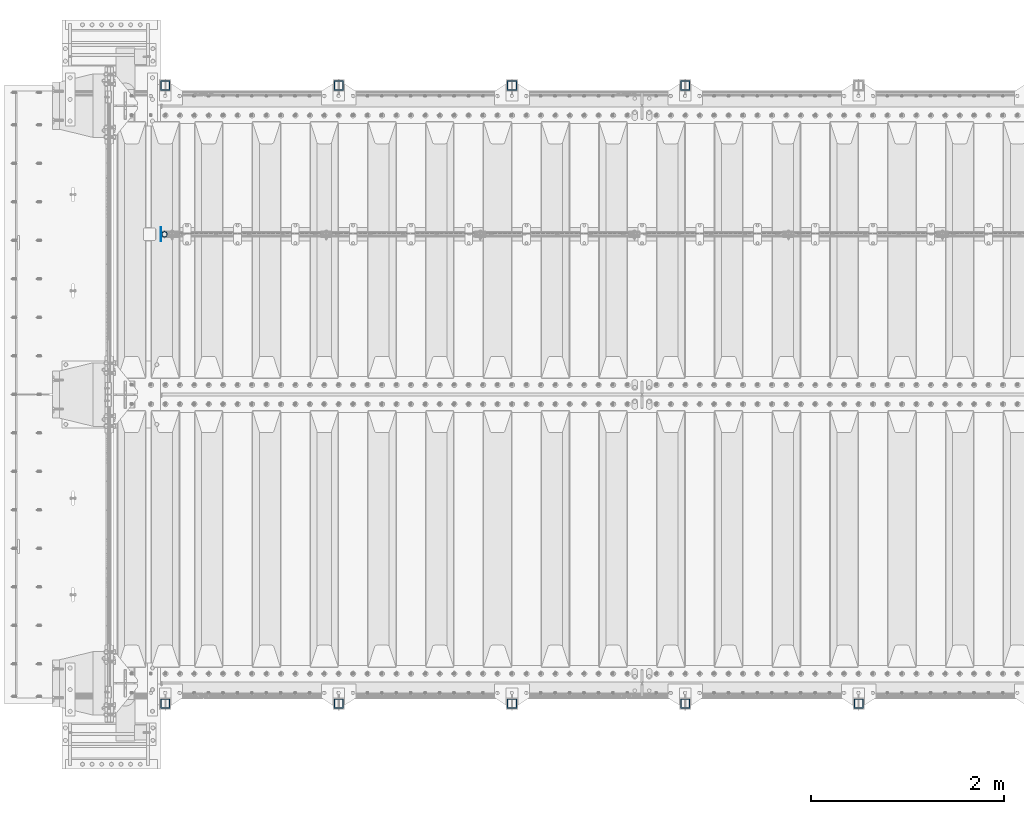
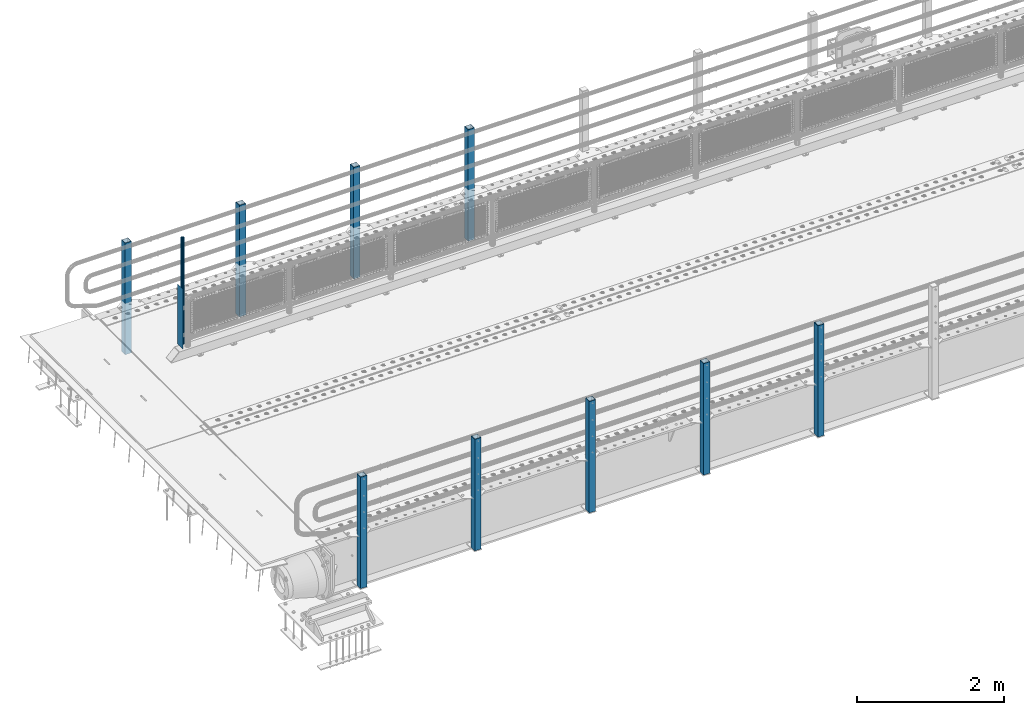
# One storey, part 50 of 208: 11 columns.
"""IFC2X3 building model written with IfcOpenShell, lengths in millimetres."""

from ifc_helpers import new_model, si_unit, frame, origin_with_axes, place, context, subcontext, project, spatial, faceted_brep, material, type_object, element, save


model = new_model("IFC2X3")

# Units and contexts
model_context = context("Model", 3, precision=1e-05, world=origin_with_axes())
body_context = subcontext(model_context, "Body", "Model", "MODEL_VIEW")
ifc_project = project(units=[si_unit("LENGTHUNIT", "METRE", prefix="MILLI"), si_unit("AREAUNIT", "SQUARE_METRE"), si_unit("VOLUMEUNIT", "CUBIC_METRE"), si_unit("MASSUNIT", "GRAM", prefix="KILO"), si_unit("TIMEUNIT", "SECOND"), si_unit("PLANEANGLEUNIT", "RADIAN"), si_unit("SOLIDANGLEUNIT", "STERADIAN"), si_unit("THERMODYNAMICTEMPERATUREUNIT", "DEGREE_CELSIUS"), si_unit("LUMINOUSINTENSITYUNIT", "LUMEN")], contexts=[model_context])

# Site, building, storey
site_placement = place(None, origin_with_axes())
site = spatial("IfcSite", under=ifc_project, at=site_placement, CompositionType="ELEMENT")
building_placement = place(site_placement, origin_with_axes())
building = spatial("IfcBuilding", under=site, at=building_placement, Name="Standard", CompositionType="ELEMENT")
storey_placement = place(building_placement, origin_with_axes())
storey = spatial("IfcBuildingStorey", under=building, at=storey_placement, Name="Undefined", CompositionType="ELEMENT", Elevation=0.0)

# Columns
ifc_material_1 = material(Name="Misc_Undefined")
column_type_1 = type_object("IfcColumnType", PredefinedType="NOTDEFINED")
column_1_placement = place(storey_placement, frame((-41909.0, 4664.5, 238.02), z_axis=(1.0, 0.0, 0.0), x_axis=(0.0, 0.0, 1.0)))
element("IfcColumn", 1, at=column_1_placement, inside=storey, type_object=column_type_1, material=ifc_material_1, context=body_context, shape_type="Brep", body=[
    faceted_brep([(0.0, -25.3500000000004, 0.0), (0.0, -23.4203461491616, 9.70102501045403), (1761.98, -23.4203461491616, 9.70102501045767), (1761.98, -25.3500000000004, 0.0), (0.0, -17.9251569030794, 17.9251569030785), (1761.98, -17.9251569030794, 17.9251569030821), (0.0, -9.70102501045494, 23.4203461491597), (1761.98, -9.70102501045494, 23.4203461491634), (0.0, 0.0, 25.3499999999985), (1761.98, 0.0, 25.3499999999985), (0.0, 9.70102501045494, 23.4203461491597), (1761.98, 9.70102501045494, 23.4203461491634), (0.0, 17.9251569030794, 17.9251569030785), (1761.98, 17.9251569030794, 17.9251569030821), (0.0, 23.4203461491616, 9.70102501045403), (1761.98, 23.4203461491616, 9.70102501045767), (0.0, 25.3500000000004, 0.0), (1761.98, 25.3500000000004, 0.0), (0.0, 23.4203461491616, -9.70102501045403), (1761.98, 23.4203461491616, -9.70102501045767), (0.0, 17.9251569030794, -17.9251569030785), (1761.98, 17.9251569030794, -17.9251569030821), (0.0, 9.70102501045494, -23.4203461491597), (1761.98, 9.70102501045494, -23.4203461491634), (0.0, 0.0, -25.3499999999985), (1761.98, 0.0, -25.3499999999985), (0.0, -9.70102501045494, -23.4203461491597), (1761.98, -9.70102501045494, -23.4203461491634), (0.0, -17.9251569030794, -17.9251569030785), (1761.98, -17.9251569030794, -17.9251569030821), (0.0, -23.4203461491616, -9.70102501045403), (1761.98, -23.4203461491616, -9.70102501045767), (0.0, -30.1499999999996, 0.0), (0.0, -27.8549679052148, -11.5379054858058), (1761.98, -27.8549679052148, -11.5379054858058), (1761.98, -30.1499999999996, 0.0), (0.0, -21.3192694527743, -21.3192694527752), (1761.98, -21.3192694527743, -21.3192694527752), (0.0, -11.5379054858076, -27.8549679052157), (1761.98, -11.5379054858076, -27.8549679052157), (0.0, 0.0, -30.1500000000015), (1761.98, 0.0, -30.1500000000015), (0.0, 11.5379054858076, -27.8549679052157), (1761.98, 11.5379054858076, -27.8549679052157), (0.0, 21.3192694527743, -21.3192694527752), (1761.98, 21.3192694527743, -21.3192694527752), (0.0, 27.8549679052157, -11.5379054858058), (1761.98, 27.8549679052157, -11.5379054858058), (0.0, 30.1499999999996, 0.0), (1761.98, 30.1499999999996, 0.0), (0.0, 27.8549679052157, 11.5379054858058), (1761.98, 27.8549679052157, 11.5379054858058), (0.0, 21.3192694527743, 21.3192694527752), (1761.98, 21.3192694527743, 21.3192694527752), (0.0, 11.5379054858076, 27.8549679052157), (1761.98, 11.5379054858076, 27.8549679052157), (0.0, 0.0, 30.1500000000015), (1761.98, 0.0, 30.1500000000015), (0.0, -11.5379054858076, 27.8549679052157), (1761.98, -11.5379054858076, 27.8549679052157), (0.0, -21.3192694527743, 21.3192694527752), (1761.98, -21.3192694527743, 21.3192694527752), (0.0, -27.8549679052157, 11.5379054858058), (1761.98, -27.8549679052157, 11.5379054858058)], [[[0, 1, 2, 3]], [[1, 4, 5, 2]], [[4, 6, 7, 5]], [[6, 8, 9, 7]], [[8, 10, 11, 9]], [[10, 12, 13, 11]], [[12, 14, 15, 13]], [[14, 16, 17, 15]], [[16, 18, 19, 17]], [[18, 20, 21, 19]], [[20, 22, 23, 21]], [[22, 24, 25, 23]], [[24, 26, 27, 25]], [[26, 28, 29, 27]], [[28, 30, 31, 29]], [[30, 0, 3, 31]], [[32, 33, 34, 35]], [[33, 36, 37, 34]], [[36, 38, 39, 37]], [[38, 40, 41, 39]], [[40, 42, 43, 41]], [[42, 44, 45, 43]], [[44, 46, 47, 45]], [[46, 48, 49, 47]], [[48, 50, 51, 49]], [[50, 52, 53, 51]], [[52, 54, 55, 53]], [[54, 56, 57, 55]], [[56, 58, 59, 57]], [[58, 60, 61, 59]], [[60, 62, 63, 61]], [[62, 32, 35, 63]], [[37, 39, 41, 43, 45, 47, 49, 51, 53, 55, 57, 59, 61, 63, 35, 34], [5, 7, 9, 11, 13, 15, 17, 19, 21, 23, 25, 27, 29, 31, 3, 2]], [[62, 60, 58, 56, 54, 52, 50, 48, 46, 44, 42, 40, 38, 36, 33, 32], [30, 28, 26, 24, 22, 20, 18, 16, 14, 12, 10, 8, 6, 4, 1, 0]]]),
])
column_type_2 = type_object("IfcColumnType", PredefinedType="NOTDEFINED")
column_2_placement = place(storey_placement, frame((-41945.5, 4664.5, 200.0), z_axis=(0.0, 1.0, 0.0), x_axis=(0.0, 0.0, 1.0)))
element("IfcColumn", 2, at=column_2_placement, inside=storey, type_object=column_type_2, material=ifc_material_1, context=body_context, shape_type="Brep", body=[
    faceted_brep([(0.0, 1.5, -75.0), (0.0, 1.5, 75.0), (1000.0, 1.5, 75.0), (1000.0, 1.5, -75.0), (0.0, -1.5, 75.0), (1000.0, -1.5, 75.0), (0.0, -1.5, -75.0), (1000.0, -1.5, -75.0)], [[[0, 1, 2, 3]], [[1, 4, 5, 2]], [[4, 6, 7, 5]], [[6, 0, 3, 7]], [[5, 7, 3, 2]], [[6, 4, 1, 0]]]),
])
ifc_material_2 = material()
column_type_3 = type_object("IfcColumnType", PredefinedType="NOTDEFINED")
for number, where, z_axis, x_axis in (
    (3, (-36499.9999999999, 6210.00000000021, -844.999999999998), (0.0, -1.0, 0.0), (0.0, 0.0, 1.0)),
    (4, (-38299.9999999999, 6210.00000000021, -844.999999999998), (0.0, -1.0, 0.0), (0.0, 0.0, 1.0)),
    (5, (-40099.9999999999, 6210.00000000021, -844.999999999998), (0.0, -1.0, 0.0), (0.0, 0.0, 1.0)),
    (6, (-41899.9999999999, 6210.00000000021, -844.999999999998), (0.0, -1.0, 0.0), (0.0, 0.0, 1.0)),
    (7, (-34700.0000000001, -210.000000000206, -844.999999999998), (0.0, 1.0, 0.0), (0.0, 0.0, 1.0)),
    (8, (-36500.0000000001, -210.000000000206, -844.999999999998), (0.0, 1.0, 0.0), (0.0, 0.0, 1.0)),
    (9, (-38300.0000000001, -210.000000000206, -844.999999999998), (0.0, 1.0, 0.0), (0.0, 0.0, 1.0)),
    (10, (-40100.0000000001, -210.000000000206, -844.999999999998), (0.0, 1.0, 0.0), (0.0, 0.0, 1.0)),
    (11, (-41900.0000000001, -210.000000000206, -844.999999999998), (0.0, 1.0, 0.0), (0.0, 0.0, 1.0)),
):
    element("IfcColumn", number, at=place(storey_placement, frame(where, z_axis=z_axis, x_axis=x_axis)), inside=storey, type_object=column_type_3, material=ifc_material_2, context=body_context, shape_type="Brep", body=[
        faceted_brep([(0.0, 40.0, -40.0), (0.0, -40.0, -40.0), (1855.0, -40.0, -40.0), (1855.0, 40.0, -40.0), (0.0, -40.0, 40.0), (1855.0, -40.0, 40.0), (0.0, 40.0, 40.0), (1855.0, 40.0, 40.0), (0.0, 50.0, -50.0), (0.0, 50.0, 50.0), (1855.0, 50.0, 50.0), (1855.0, 50.0, -50.0), (0.0, -50.0, 50.0), (1855.0, -50.0, 50.0), (0.0, -50.0, -50.0), (1855.0, -50.0, -50.0)], [[[0, 1, 2, 3]], [[1, 4, 5, 2]], [[4, 6, 7, 5]], [[6, 0, 3, 7]], [[8, 9, 10, 11]], [[9, 12, 13, 10]], [[12, 14, 15, 13]], [[14, 8, 11, 15]], [[13, 15, 11, 10], [5, 7, 3, 2]], [[14, 12, 9, 8], [6, 4, 1, 0]]]),
    ])

save(model, "model.ifc")
